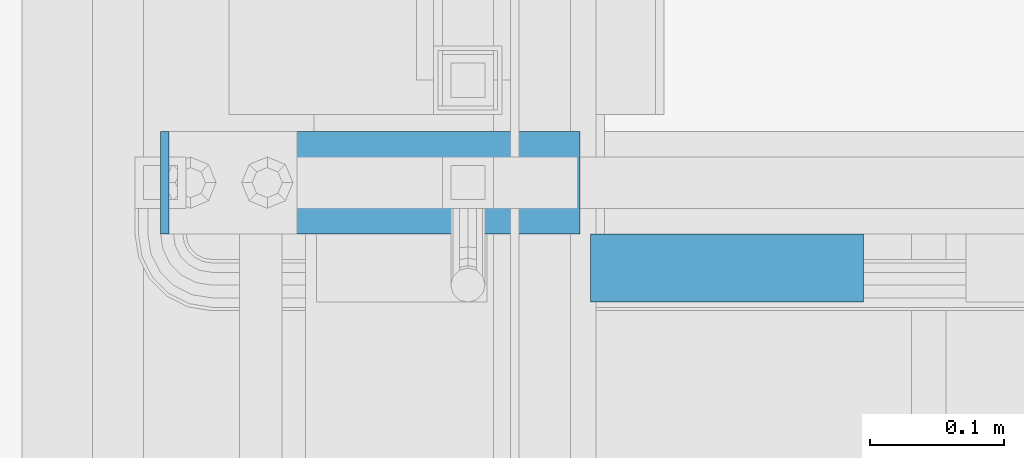
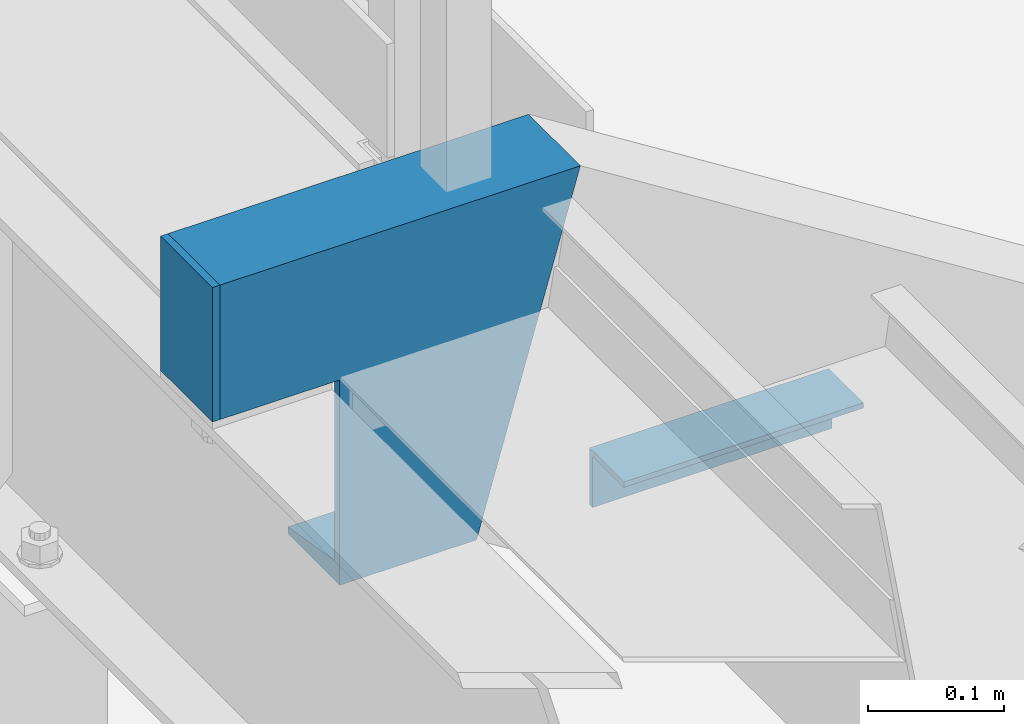
# One storey, part 2132 of 3843: 3 beams, 1 element without a shape of its own.
"""IFC2X3 building model written with IfcOpenShell, lengths in millimetres."""

from ifc_helpers import new_model, si_unit, frame, origin_with_axes, place, context, subcontext, project, spatial, faceted_brep, material, type_object, element, aggregate, save


model = new_model("IFC2X3")

# Units and contexts
model_context = context("Model", 3, precision=1e-05, world=origin_with_axes())
body_context = subcontext(model_context, "Body", "Model", "MODEL_VIEW")
ifc_project = project(units=[si_unit("LENGTHUNIT", "METRE", prefix="MILLI"), si_unit("AREAUNIT", "SQUARE_METRE"), si_unit("VOLUMEUNIT", "CUBIC_METRE"), si_unit("MASSUNIT", "GRAM", prefix="KILO"), si_unit("TIMEUNIT", "SECOND"), si_unit("PLANEANGLEUNIT", "RADIAN"), si_unit("SOLIDANGLEUNIT", "STERADIAN"), si_unit("THERMODYNAMICTEMPERATUREUNIT", "DEGREE_CELSIUS"), si_unit("LUMINOUSINTENSITYUNIT", "LUMEN")], contexts=[model_context])

# Site, building, storey
site_placement = place(None, origin_with_axes())
site = spatial("IfcSite", under=ifc_project, at=site_placement, CompositionType="ELEMENT")
building_placement = place(site_placement, origin_with_axes())
building = spatial("IfcBuilding", under=site, at=building_placement, Name="Undefined", CompositionType="ELEMENT")
storey_placement = place(building_placement, origin_with_axes())
storey = spatial("IfcBuildingStorey", under=building, at=storey_placement, Name="Undefined", CompositionType="ELEMENT", Elevation=0.0)

# Assembly, beams
assembly_placement = place(storey_placement, origin_with_axes())
assembly = element("IfcElementAssembly", 1, at=assembly_placement, inside=storey, Name="STAIR", AssemblyPlace="NOTDEFINED", PredefinedType="RIGID_FRAME")
ifc_material = material(Name="STEEL/A36")
beam_type_1 = type_object("IfcBeamType", PredefinedType="NOTDEFINED")
beam_1_placement = place(assembly_placement, frame((55883.175, 27254.2, 33324.8000000003), z_axis=(0.0, -1.0, 0.0), x_axis=(0.0, 0.0, -1.0)))
beam_1 = element("IfcBeam", 2, at=beam_1_placement, type_object=beam_type_1, material=ifc_material, Name="PLATE", context=body_context, shape_type="Brep", body=[
    faceted_brep([(0.0, 3.17500000000291, -38.0999999999985), (0.0, 3.17500000000291, 38.0999999999985), (120.650000000831, 3.17500000000291, 38.0999999999985), (120.650000000831, 3.17500000000291, -38.0999999999985), (0.0, -3.17500000000291, 38.0999999999985), (120.650000000831, -3.17500000000291, 38.0999999999985), (0.0, -3.17500000000291, -38.0999999999985), (120.650000000831, -3.17500000000291, -38.0999999999985)], [[[0, 1, 2, 3]], [[1, 4, 5, 2]], [[4, 6, 7, 5]], [[6, 0, 3, 7]], [[5, 7, 3, 2]], [[6, 4, 1, 0]]]),
])
beam_type_2 = type_object("IfcBeamType", Name="L2X2X3/16", PredefinedType="NOTDEFINED")
beam_2_placement = place(assembly_placement, frame((56199.6696627313, 27190.7000000518, 33043.812499978), z_axis=(0.0, -1.0, 0.0), x_axis=(1.0, 0.0, 0.0)))
beam_2 = element("IfcBeam", 3, at=beam_2_placement, type_object=beam_type_2, material=ifc_material, Name="ANGLE", ObjectType="L2X2X3/16", context=body_context, shape_type="Brep", body=[
    faceted_brep([(0.0, 25.4000000000015, -25.4000000000015), (0.0, 25.4000000000015, 25.4000000000015), (203.199999999997, 25.4000000000015, 25.4000000000015), (203.199999999997, 25.4000000000015, -25.4000000000015), (0.0, 20.6375000000007, 25.4000000000015), (203.199999999997, 20.6375000000007, 25.4000000000015), (0.0, 20.6375000000007, -20.6375000000007), (203.199999999997, 20.6375000000007, -20.6375000000007), (0.0, -25.4000000000015, -20.6375000000007), (203.199999999997, -25.4000000000015, -20.6375000000007), (0.0, -25.4000000000015, -25.4000000000015), (203.199999999997, -25.4000000000015, -25.4000000000015)], [[[0, 1, 2, 3]], [[1, 4, 5, 2]], [[4, 6, 7, 5]], [[6, 8, 9, 7]], [[8, 10, 11, 9]], [[10, 0, 3, 11]], [[5, 7, 9, 11, 3, 2]], [[10, 8, 6, 4, 1, 0]]]),
])
beam_type_3 = type_object("IfcBeamType", Name="C12X20.7", PredefinedType="NOTDEFINED")
beam_3_placement = place(assembly_placement, frame((56192.1406713475, 27254.2000000005, 33172.4000000005), z_axis=(0.0, 0.0, 1.0), x_axis=(-1.0, 0.0, 0.0)))
beam_3 = element("IfcBeam", 4, at=beam_3_placement, type_object=beam_type_3, material=ifc_material, Name="STAIR", ObjectType="C12X20.7", context=body_context, shape_type="Brep", body=[
    faceted_brep([(204.190671347453, 30.1624999999985, -134.674927499997), (204.190671347453, -38.0999999999985, -146.047460000002), (204.190671347453, -38.0999999999985, -152.400000000001), (204.190671347453, 38.0999999999985, -152.400000000001), (204.190671347453, 38.0999999999985, 31.7499999990396), (204.190671347453, 30.1624999999985, 31.7499999990396), (305.790671347451, 30.1624999999985, 31.7499999990396), (305.790671347451, 38.0999999999985, 31.7499999990396), (0.0, -38.0999999999985, 152.400000000001), (1.83590131863457, -38.0999999999985, 146.047460000002), (305.790671347451, -38.0999999999985, 146.047460000002), (305.790671347451, -38.0999999999985, 152.400000000001), (0.0, 38.0999999999985, 152.400000000001), (305.790671347451, 38.0999999999985, 152.400000000001), (88.0880557814089, -38.0999999999985, -152.400000000001), (86.2521538732108, -38.0999999999985, -146.047460000002), (82.9654600282593, 30.1624999999985, -134.674927499997), (5.12259516357881, 30.1624999999985, 134.674927499997), (88.0880557814089, 38.0999999999985, -152.400000000001), (305.790671347451, 30.1624999999985, 134.674927499997)], [[[0, 1, 2, 3, 4, 5]], [[6, 5, 4, 7]], [[8, 9, 10, 11]], [[12, 8, 11, 13]], [[14, 15, 16, 17, 9, 8, 12, 18]], [[9, 17, 19, 10]], [[13, 11, 10, 19, 6, 7]], [[3, 18, 12, 13, 7, 4]], [[14, 18, 3, 2]], [[15, 14, 2, 1]], [[16, 15, 1, 0]], [[19, 17, 16, 0, 5, 6]]]),
])
aggregate(assembly, [beam_1, beam_2, beam_3])

save(model, "model.ifc")
